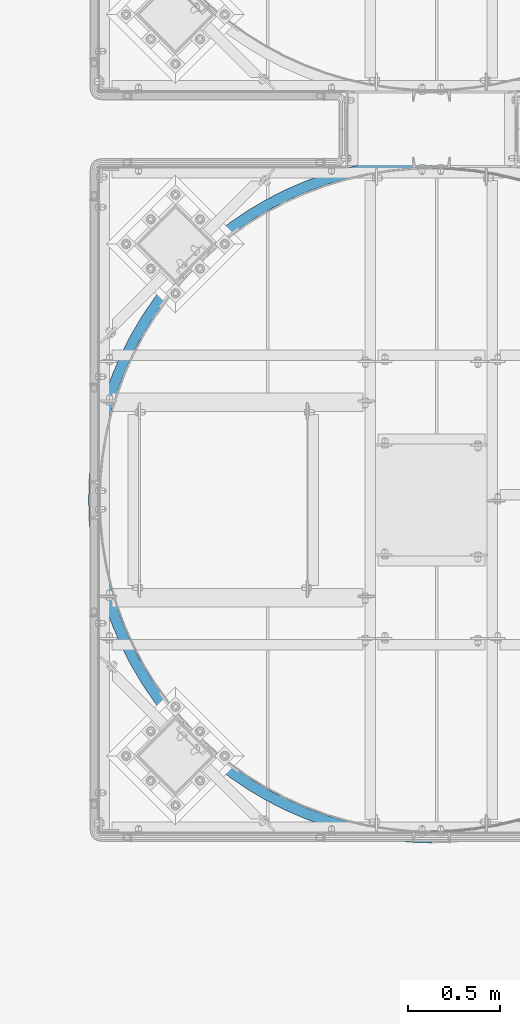
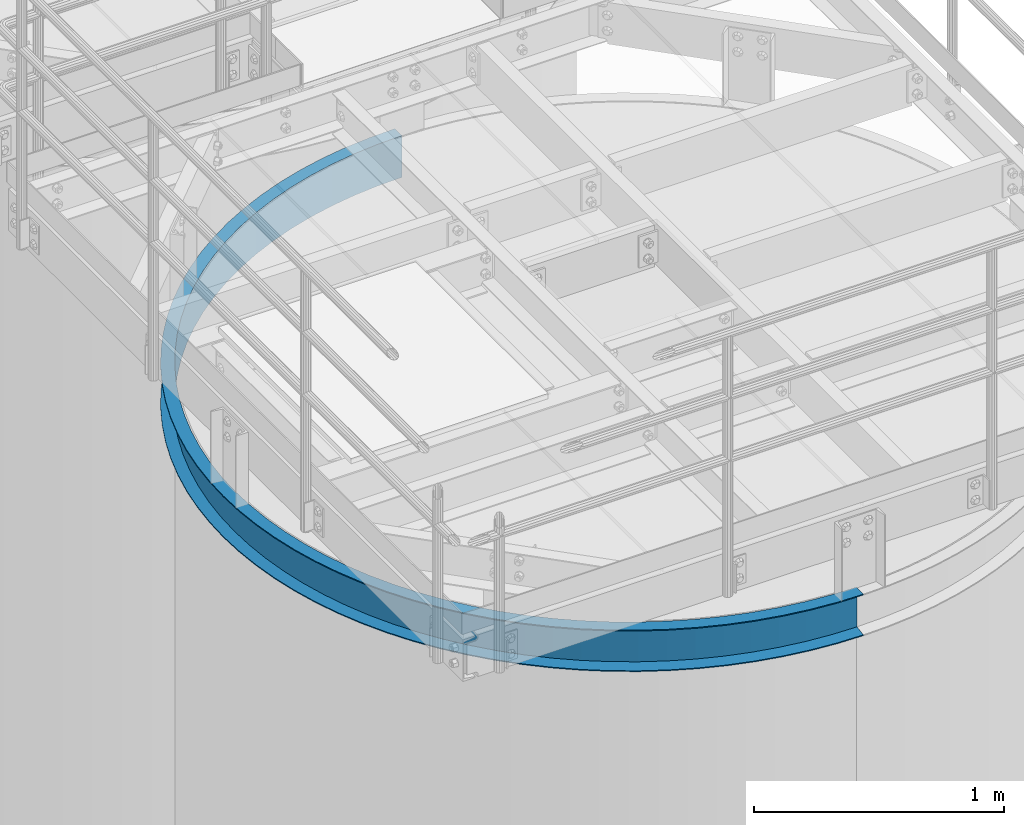
# One storey, part 920 of 1876: 1 beam, 1 element without a shape of its own.
"""IFC2X3 building model written with IfcOpenShell, lengths in millimetres."""

from ifc_helpers import new_model, si_unit, frame, origin_with_axes, place, context, subcontext, project, spatial, faceted_brep, material, type_object, element, aggregate, save


model = new_model("IFC2X3")

# Units and contexts
model_context = context("Model", 3, precision=1e-05, world=origin_with_axes())
body_context = subcontext(model_context, "Body", "Model", "MODEL_VIEW")
ifc_project = project(units=[si_unit("LENGTHUNIT", "METRE", prefix="MILLI"), si_unit("AREAUNIT", "SQUARE_METRE"), si_unit("VOLUMEUNIT", "CUBIC_METRE"), si_unit("MASSUNIT", "GRAM", prefix="KILO"), si_unit("TIMEUNIT", "SECOND"), si_unit("PLANEANGLEUNIT", "RADIAN"), si_unit("SOLIDANGLEUNIT", "STERADIAN"), si_unit("THERMODYNAMICTEMPERATUREUNIT", "DEGREE_CELSIUS"), si_unit("LUMINOUSINTENSITYUNIT", "LUMEN")], contexts=[model_context])

# Site, building, storey
site_placement = place(None, origin_with_axes())
site = spatial("IfcSite", under=ifc_project, at=site_placement, CompositionType="ELEMENT")
building_placement = place(site_placement, origin_with_axes())
building = spatial("IfcBuilding", under=site, at=building_placement, Name="Undefined", CompositionType="ELEMENT")
storey_placement = place(building_placement, origin_with_axes())
storey = spatial("IfcBuildingStorey", under=building, at=storey_placement, Name="Undefined", CompositionType="ELEMENT", Elevation=0.0)

# Assembly, beam
assembly_placement = place(storey_placement, origin_with_axes())
assembly = element("IfcElementAssembly", 1, at=assembly_placement, inside=storey, Name="CHANNEL", AssemblyPlace="NOTDEFINED", PredefinedType="RIGID_FRAME")
ifc_material = material(Name="STEEL/A36")
beam_type = type_object("IfcBeamType", Name="C8X11.5", PredefinedType="NOTDEFINED")
beam_placement = place(assembly_placement, frame((5161.39583081535, -15425.2699805693, 7518.41566278096), z_axis=(0.0, 0.0, -1.0), x_axis=(-0.707106781186548, 0.707106781186547, 0.0)))
beam = element("IfcBeam", 2, at=beam_placement, type_object=beam_type, material=ifc_material, Name="CHANNEL", ObjectType="C8X11.5", context=body_context, shape_type="Brep", body=[
    faceted_brep([(-40.4111525448152, -11.8361525448254, -101.6), (-40.4111525448152, -11.8361525448254, -96.8355949999996), (-4.49012806054634, 24.0848719394708, -88.3723149999996), (-4.49012806054634, 24.0848719394708, 88.3723149999996), (-40.4111525448152, -11.8361525448254, 96.8355949999996), (-40.4111525448152, -11.8361525448254, 101.6), (0.0, 28.5749999999998, 101.6), (0.0, 28.5749999999998, -101.6), (83.1681455805992, -49.5250871930584, 101.6), (83.168145580601, -49.5250871930593, -101.6), (45.3741724773627, -92.3939348224612, -101.6), (45.3741724773627, -92.3939348224612, -96.8355949999996), (78.9688152357958, -54.2882924852147, -88.3723149999996), (78.9688152357958, -54.2882924852147, 88.3723149999996), (45.3741724773627, -92.3939348224612, 96.8355949999996), (45.3741724773627, -92.3939348224612, 101.6), (136.048484757743, -167.406249592315, 96.8355949999996), (136.048484757743, -167.406249592315, 101.6), (167.184163083306, -127.266374963614, 88.3723149999996), (167.184163083306, -127.266374963614, -88.3723149999996), (136.048484757743, -167.406249592315, -96.8355949999996), (136.048484757743, -167.406249592315, -101.6), (171.076122874001, -122.248890635026, 101.6), (171.076122874001, -122.248890635026, -101.6), (231.253934210907, -236.577057517859, 96.8355949999996), (231.253934210907, -236.577057517859, 101.6), (259.807769805786, -194.561364344698, 88.3723149999996), (259.807769805786, -194.561364344698, -88.3723149999996), (231.253934210907, -236.577057517859, -96.8355949999996), (231.253934210907, -236.577057517859, -101.6), (263.376999255146, -189.309402698053, 101.6), (263.376999255146, -189.309402698053, -101.6), (330.614788423094, -299.633373021349, 96.8355949999996), (330.614788423094, -299.633373021349, 101.6), (356.474092343207, -255.907678049534, 88.3723149999996), (356.474092343207, -255.907678049534, -88.3723149999996), (330.614788423094, -299.633373021349, -96.8355949999996), (330.614788423094, -299.633373021349, -101.6), (359.706505333223, -250.441966178058, 101.6), (359.706505333223, -250.441966178058, -101.6), (433.738915496391, -356.326341633181, 96.8355949999996), (433.738915496391, -356.326341633181, 101.6), (456.801632883155, -311.063210204398, 88.3723149999996), (456.801632883155, -311.063210204398, -88.3723149999996), (433.738915496391, -356.326341633181, -96.8355949999996), (433.738915496391, -356.326341633181, -101.6), (459.684472556501, -305.4053187758, 101.6), (459.684472556501, -305.4053187758, -101.6), (540.219331614169, -406.432222106796, 96.8355949999996), (540.219331614169, -406.432222106796, 101.6), (560.39444445841, -359.810287122038, 88.3723149999996), (560.39444445841, -359.810287122038, -88.3723149999996), (540.219331614169, -406.432222106796, -96.8355949999996), (540.219331614169, -406.432222106796, -101.6), (562.91633356394, -353.982545248944, 101.6), (562.91633356394, -353.982545248944, -101.6), (649.635807220287, -449.753269423169, 96.8355949999996), (649.635807220287, -449.753269423169, 101.6), (666.843693568744, -401.956526360284, 88.3723149999996), (666.843693568744, -401.956526360284, -88.3723149999996), (649.635807220287, -449.753269423169, -96.8355949999996), (649.635807220287, -449.753269423169, -101.6), (668.9946793623, -395.981933477424, 101.6), (668.9946793623, -395.981933477424, -101.6), (761.556525473163, -486.118515200043, 96.8355949999996), (761.556525473163, -486.118515200043, 101.6), (775.729273659952, -437.335595967645, 88.3723149999996), (775.729273659952, -437.335595967645, -88.3723149999996), (761.556525473163, -486.118515200043, -96.8355949999996), (761.556525473163, -486.118515200043, -101.6), (777.500867183298, -431.237731063595, 101.6), (777.500867183298, -431.237731063595, -101.6), (875.539786429559, -515.384442426039, 96.8355949999996), (875.539786429559, -515.384442426039, 101.6), (886.621463092501, -465.807870919541, 88.3723149999996), (886.621463092501, -465.807870919541, -88.3723149999996), (875.539786429559, -515.384442426039, -96.8355949999996), (875.539786429559, -515.384442426039, -101.6), (888.006672675367, -459.610799481228, 101.6), (888.006672675367, -459.610799481228, -101.6), (991.135750232484, -537.435551856724, 96.8355949999996), (991.135750232484, -537.435551856724, 101.6), (999.082621056526, -487.260984154484, 88.3723149999996), (999.082621056526, -487.260984154484, -88.3723149999996), (991.135750232484, -537.435551856724, -96.8355949999996), (991.135750232484, -537.435551856724, -101.6), (1000.07597990953, -480.989163191702, 101.6), (1000.07597990953, -480.989163191702, -101.6), (1107.88821242358, -552.184817837371, 96.8355949999996), (1107.88821242358, -552.184817837371, 101.6), (1112.66891474016, -501.610270035526, 88.3723149999996), (1112.66891474016, -501.610270035526, -88.3723149999996), (1107.88821242358, -552.184817837371, -96.8355949999996), (1107.88821242358, -552.184817837371, -101.6), (1113.26650252974, -495.288451560295, 101.6), (1113.26650252974, -495.288451560295, -101.6), (1225.33640437371, -559.574031753455, 96.8355949999996), (1225.33640437371, -559.574031753455, 101.6), (1226.93207093488, -508.799098486866, 88.3723149999996), (1226.93207093488, -508.799098486866, -88.3723149999996), (1225.33640437371, -559.574031753455, -96.8355949999996), (1225.33640437371, -559.574031753455, -101.6), (1227.13152925503, -502.452231828542, 101.6), (1227.13152925503, -502.452231828542, -101.6), (1343.01681172622, -559.574031753454, 96.8355949999996), (1343.01681172622, -559.574031753454, 101.6), (1341.42114516505, -508.799098486867, 88.3723149999996), (1341.42114516505, -508.799098486867, -88.3723149999996), (1343.01681172622, -559.574031753454, -96.8355949999996), (1343.01681172622, -559.574031753454, -101.6), (1341.2216868449, -502.452231828544, 101.6), (1341.2216868449, -502.452231828544, -101.6), (1460.46500367634, -552.184817837373, 96.8355949999996), (1460.46500367634, -552.184817837373, 101.6), (1455.68430135976, -501.610270035527, 88.3723149999996), (1455.68430135976, -501.610270035527, -88.3723149999996), (1460.46500367634, -552.184817837373, -96.8355949999996), (1460.46500367634, -552.184817837373, -101.6), (1455.08671357019, -495.288451560297, 101.6), (1455.08671357019, -495.288451560297, -101.6), (1577.21746586744, -537.435551856726, 96.8355949999996), (1577.21746586744, -537.435551856726, 101.6), (1569.2705950434, -487.260984154484, 88.3723149999996), (1569.2705950434, -487.260984154484, -88.3723149999996), (1577.21746586744, -537.435551856726, -96.8355949999996), (1577.21746586744, -537.435551856726, -101.6), (1568.27723619039, -480.989163191705, 101.6), (1568.27723619039, -480.989163191705, -101.6), (1692.81342967037, -515.384442426042, 96.8355949999996), (1692.81342967037, -515.384442426042, 101.6), (1681.73175300743, -465.807870919543, 88.3723149999996), (1681.73175300743, -465.807870919543, -88.3723149999996), (1692.81342967037, -515.384442426042, -96.8355949999996), (1692.81342967037, -515.384442426042, -101.6), (1680.34654342456, -459.610799481231, 101.6), (1680.34654342456, -459.610799481231, -101.6), (1806.79669062676, -486.118515200047, 96.8355949999996), (1806.79669062676, -486.118515200047, 101.6), (1792.62394243998, -437.335595967647, 88.3723149999996), (1792.62394243998, -437.335595967647, -88.3723149999996), (1806.79669062676, -486.118515200047, -96.8355949999996), (1806.79669062676, -486.118515200047, -101.6), (1790.85234891663, -431.237731063598, 101.6), (1790.85234891663, -431.237731063598, -101.6), (1918.71740887964, -449.753269423174, 96.8355949999996), (1918.71740887964, -449.753269423174, 101.6), (1901.50952253118, -401.956526360288, 88.3723149999996), (1901.50952253118, -401.956526360288, -88.3723149999996), (1918.71740887964, -449.753269423174, -96.8355949999996), (1918.71740887964, -449.753269423174, -101.6), (1899.35853673763, -395.981933477428, 101.6), (1899.35853673763, -395.981933477428, -101.6), (2028.13388448576, -406.432222106803, 96.8355949999996), (2028.13388448576, -406.432222106803, 101.6), (2007.95877164152, -359.810287122044, 88.3723149999996), (2007.95877164152, -359.810287122044, -88.3723149999996), (2028.13388448576, -406.432222106803, -96.8355949999996), (2028.13388448576, -406.432222106803, -101.6), (2005.43688253599, -353.982545248949, 101.6), (2005.43688253599, -353.982545248949, -101.6), (2134.61430060353, -356.326341633187, 96.8355949999996), (2134.61430060353, -356.326341633187, 101.6), (2111.55158321677, -311.063210204405, 88.3723149999996), (2111.55158321677, -311.063210204405, -88.3723149999996), (2134.61430060353, -356.326341633187, -96.8355949999996), (2134.61430060353, -356.326341633187, -101.6), (2108.66874354343, -305.405318775807, 101.6), (2108.66874354343, -305.405318775807, -101.6), (2237.73842767683, -299.633373021357, 96.8355949999996), (2237.73842767683, -299.633373021357, 101.6), (2211.87912375672, -255.907678049542, 88.3723149999996), (2211.87912375672, -255.907678049542, -88.3723149999996), (2237.73842767683, -299.633373021357, -96.8355949999996), (2237.73842767683, -299.633373021357, -101.6), (2208.64671076671, -250.441966178065, 101.6), (2208.64671076671, -250.441966178065, -101.6), (2337.09928188902, -236.577057517868, 96.8355949999996), (2337.09928188902, -236.577057517868, 101.6), (2308.54544629414, -194.561364344705, 88.3723149999996), (2308.54544629414, -194.561364344705, -88.3723149999996), (2337.09928188902, -236.577057517868, -96.8355949999996), (2337.09928188902, -236.577057517868, -101.6), (2304.97621684478, -189.30940269806, 101.6), (2304.97621684478, -189.30940269806, -101.6), (2432.30473134219, -167.406249592324, 96.8355949999996), (2432.30473134219, -167.406249592324, 101.6), (2401.16905301662, -127.266374963622, 88.3723149999996), (2401.16905301662, -127.266374963622, -88.3723149999996), (2432.30473134219, -167.406249592324, -96.8355949999996), (2432.30473134219, -167.406249592324, -101.6), (2397.27709322593, -122.248890635034, 101.6), (2397.27709322593, -122.248890635034, -101.6), (2522.97904362256, -92.3939348224685, 96.8355949999996), (2522.97904362256, -92.3939348224685, 101.6), (2489.38440086413, -54.2882924852247, 88.3723149999996), (2489.38440086413, -54.2882924852247, -88.3723149999996), (2522.97904362256, -92.3939348224685, -96.8355949999996), (2522.97904362256, -92.3939348224685, -101.6), (2485.18507051933, -49.5250871930684, 101.6), (2485.18507051933, -49.5250871930684, -101.6), (2608.76436864474, -11.8361525448345, 96.8355949999996), (2608.76436864474, -11.8361525448345, 101.6), (2572.84334416047, 24.0848719394626, 88.3723149999996), (2572.84334416047, 24.0848719394626, -88.3723149999996), (2608.76436864474, -11.8361525448345, -96.8355949999996), (2608.76436864474, -11.8361525448345, -101.6), (2568.35321609994, 28.5749999999989, 101.6), (2568.35321609993, 28.5749999999989, -101.6), (2764.3344656923, 164.623484757718, 101.6), (2833.50527361787, 259.828934210873, 101.6), (2896.56158912139, 359.189788423056, 101.6), (2953.25455773324, 462.313915496351, 101.6), (3003.36043820688, 568.794331614128, 101.6), (3046.68148552328, 678.210807220248, 101.6), (3083.04673130017, 790.131525473126, 101.6), (3112.31265852618, 904.114786429529, 101.6), (3134.36376795688, 1019.71075023246, 101.6), (3149.11303393754, 1136.46321242357, 101.6), (3156.50224785364, 1253.91140437371, 101.6), (3156.50224785364, 1371.59181172622, 101.6), (3149.11303393757, 1489.04000367636, 101.6), (3134.36376795692, 1605.79246586747, 101.6), (3112.31265852624, 1721.38842967041, 101.6), (3083.04673130024, 1835.37169062681, 101.6), (3046.68148552336, 1947.2924088797, 101.6), (3003.36043820698, 2056.70888448582, 101.6), (2953.25455773336, 2163.18930060361, 101.6), (2896.56158912152, 2266.31342767691, 101.6), (2833.50527361802, 2365.67428188911, 101.6), (2764.33446569245, 2460.87973134227, 101.6), (2689.32215092258, 2551.55404362265, 101.6), (2608.76436864493, 2637.33936864483, 101.6), (2568.3532161001, 2596.92821610002, 101.6), (2646.45330329319, 2513.76007051941, 101.6), (2719.17710673517, 2425.85209322601, 101.6), (2786.23761879821, 2333.55121684486, 101.6), (2847.37018227823, 2237.22171076678, 101.6), (2902.33353487598, 2137.2437435435, 101.6), (2950.91076134913, 2034.01188253605, 101.6), (2992.91014957762, 1927.93353673768, 101.6), (3028.16594716379, 1819.42734891668, 101.6), (3056.53901558143, 1708.9215434246, 101.6), (3077.9173792919, 1596.85223619042, 101.6), (3092.21666766049, 1483.66171357021, 101.6), (3099.38044792873, 1369.79668684491, 101.6), (3099.38044792872, 1255.70652925503, 101.6), (3092.21666766047, 1141.84150252973, 101.6), (3077.91737929186, 1028.65097990952, 101.6), (3056.53901558137, 916.581672675346, 101.6), (3028.16594716372, 806.075867183273, 101.6), (2992.91014957753, 697.569679362271, 101.6), (2950.91076134903, 591.49133356391, 101.6), (2902.33353487587, 488.25947255647, 101.6), (2847.3701822781, 388.281505333194, 101.6), (2786.23761879807, 291.951999255124, 101.6), (2719.17710673502, 199.651122873987, 101.6), (2646.45330329302, 111.743145580598, 101.6), (2689.32215092242, 73.9491724773488, 101.6), (2646.45330329302, 111.743145580598, -101.6), (2719.17710673502, 199.651122873987, -101.6), (2786.23761879807, 291.951999255124, -101.6), (2847.3701822781, 388.281505333194, -101.6), (2902.33353487587, 488.25947255647, -101.6), (2950.91076134903, 591.49133356391, -101.6), (2992.91014957753, 697.569679362271, -101.6), (3028.16594716372, 806.075867183273, -101.6), (3056.53901558137, 916.581672675346, -101.6), (3077.91737929186, 1028.65097990952, -101.6), (3092.21666766047, 1141.84150252973, -101.6), (3099.38044792872, 1255.70652925503, -101.6), (3099.38044792873, 1369.79668684491, -101.6), (3092.21666766049, 1483.66171357021, -101.6), (3077.9173792919, 1596.85223619042, -101.6), (3056.53901558143, 1708.9215434246, -101.6), (3028.16594716379, 1819.42734891668, -101.6), (2992.91014957762, 1927.93353673768, -101.6), (2950.91076134913, 2034.01188253605, -101.6), (2902.33353487598, 2137.2437435435, -101.6), (2847.37018227823, 2237.22171076678, -101.6), (2786.23761879821, 2333.55121684486, -101.6), (2719.17710673517, 2425.85209322601, -101.6), (2646.45330329319, 2513.76007051941, -101.6), (2568.3532161001, 2596.92821610002, -101.6), (2608.76436864493, 2637.33936864483, -101.6), (2689.32215092258, 2551.55404362265, -101.6), (2764.33446569245, 2460.87973134227, -101.6), (2833.50527361802, 2365.67428188911, -101.6), (2896.56158912152, 2266.31342767691, -101.6), (2953.25455773336, 2163.18930060361, -101.6), (3003.36043820698, 2056.70888448582, -101.6), (3046.68148552336, 1947.2924088797, -101.6), (3083.04673130024, 1835.37169062681, -101.6), (3112.31265852624, 1721.38842967041, -101.6), (3134.36376795692, 1605.79246586747, -101.6), (3149.11303393757, 1489.04000367636, -101.6), (3156.50224785364, 1371.59181172622, -101.6), (3156.50224785364, 1253.91140437371, -101.6), (3149.11303393754, 1136.46321242357, -101.6), (3134.36376795688, 1019.71075023246, -101.6), (3112.31265852618, 904.114786429529, -101.6), (3083.04673130017, 790.131525473126, -101.6), (3046.68148552328, 678.210807220248, -101.6), (3003.36043820688, 568.794331614128, -101.6), (2953.25455773324, 462.313915496351, -101.6), (2896.56158912139, 359.189788423056, -101.6), (2833.50527361787, 259.828934210873, -101.6), (2764.3344656923, 164.623484757718, -101.6), (2689.32215092242, 73.9491724773488, -101.6), (2689.32215092242, 73.9491724773488, -96.8355949999996), (2651.21650858518, 107.543815235792, -88.3723149999996), (2651.21650858518, 107.543815235792, 88.3723149999996), (2689.32215092242, 73.9491724773488, 96.8355949999996), (2764.3344656923, 164.623484757718, 96.8355949999996), (2724.19459106361, 195.75916308329, 88.3723149999996), (2724.19459106361, 195.75916308329, -88.3723149999996), (2764.3344656923, 164.623484757718, -96.8355949999996), (2833.50527361787, 259.828934210873, 96.8355949999996), (2791.48958044472, 288.382769805763, 88.3723149999996), (2791.48958044472, 288.382769805763, -88.3723149999996), (2833.50527361787, 259.828934210873, -96.8355949999996), (2896.56158912139, 359.189788423056, 96.8355949999996), (2852.83589414958, 385.049092343178, 88.3723149999996), (2852.83589414958, 385.049092343178, -88.3723149999996), (2896.56158912139, 359.189788423056, -96.8355949999996), (2953.25455773324, 462.313915496351, 96.8355949999996), (2907.99142630447, 485.376632883123, 88.3723149999996), (2907.99142630447, 485.376632883123, -88.3723149999996), (2953.25455773324, 462.313915496351, -96.8355949999996), (3003.36043820688, 568.794331614128, 96.8355949999996), (2956.73850322213, 588.969444458379, 88.3723149999996), (2956.73850322213, 588.969444458379, -88.3723149999996), (3003.36043820688, 568.794331614128, -96.8355949999996), (3046.68148552328, 678.210807220248, 96.8355949999996), (2998.88474246039, 695.418693568713, 88.3723149999996), (2998.88474246039, 695.418693568713, -88.3723149999996), (3046.68148552328, 678.210807220248, -96.8355949999996), (3083.04673130017, 790.131525473126, 96.8355949999996), (3034.26381206777, 804.304273659922, 88.3723149999996), (3034.26381206777, 804.304273659922, -88.3723149999996), (3083.04673130017, 790.131525473126, -96.8355949999996), (3112.31265852618, 904.114786429529, 96.8355949999996), (3062.73608701968, 915.196463092477, 88.3723149999996), (3062.73608701968, 915.196463092477, -88.3723149999996), (3112.31265852618, 904.114786429529, -96.8355949999996), (3134.36376795688, 1019.71075023246, 96.8355949999996), (3084.18920025464, 1027.65762105651, 88.3723149999996), (3084.18920025464, 1027.65762105651, -88.3723149999996), (3134.36376795688, 1019.71075023246, -96.8355949999996), (3149.11303393754, 1136.46321242357, 96.8355949999996), (3098.5384861357, 1141.24391474015, 88.3723149999996), (3098.5384861357, 1141.24391474015, -88.3723149999996), (3149.11303393754, 1136.46321242357, -96.8355949999996), (3156.50224785364, 1253.91140437371, 96.8355949999996), (3105.72731458705, 1255.50707093488, 88.3723149999996), (3105.72731458705, 1255.50707093488, -88.3723149999996), (3156.50224785364, 1253.91140437371, -96.8355949999996), (3156.50224785364, 1371.59181172622, 96.8355949999996), (3105.72731458705, 1369.99614516506, 88.3723149999996), (3105.72731458705, 1369.99614516506, -88.3723149999996), (3156.50224785364, 1371.59181172622, -96.8355949999996), (3149.11303393757, 1489.04000367636, 96.8355949999996), (3098.53848613572, 1484.25930135978, 88.3723149999996), (3098.53848613572, 1484.25930135978, -88.3723149999996), (3149.11303393757, 1489.04000367636, -96.8355949999996), (3134.36376795692, 1605.79246586747, 96.8355949999996), (3084.18920025468, 1597.84559504343, 88.3723149999996), (3084.18920025468, 1597.84559504343, -88.3723149999996), (3134.36376795692, 1605.79246586747, -96.8355949999996), (3112.31265852624, 1721.38842967041, 96.8355949999996), (3062.73608701974, 1710.30675300747, 88.3723149999996), (3062.73608701974, 1710.30675300747, -88.3723149999996), (3112.31265852624, 1721.38842967041, -96.8355949999996), (3083.04673130024, 1835.37169062681, 96.8355949999996), (3034.26381206784, 1821.19894244003, 88.3723149999996), (3034.26381206784, 1821.19894244003, -88.3723149999996), (3083.04673130024, 1835.37169062681, -96.8355949999996), (3046.68148552336, 1947.2924088797, 96.8355949999996), (2998.88474246048, 1930.08452253124, 88.3723149999996), (2998.88474246048, 1930.08452253124, -88.3723149999996), (3046.68148552336, 1947.2924088797, -96.8355949999996), (3003.36043820698, 2056.70888448582, 96.8355949999996), (2956.73850322223, 2036.53377164158, 88.3723149999996), (2956.73850322223, 2036.53377164158, -88.3723149999996), (3003.36043820698, 2056.70888448582, -96.8355949999996), (2953.25455773336, 2163.18930060361, 96.8355949999996), (2907.99142630458, 2140.12658321685, 88.3723149999996), (2907.99142630458, 2140.12658321685, -88.3723149999996), (2953.25455773336, 2163.18930060361, -96.8355949999996), (2896.56158912152, 2266.31342767691, 96.8355949999996), (2852.8358941497, 2240.4541237568, 88.3723149999996), (2852.8358941497, 2240.4541237568, -88.3723149999996), (2896.56158912152, 2266.31342767691, -96.8355949999996), (2833.50527361802, 2365.67428188911, 96.8355949999996), (2791.48958044486, 2337.12044629422, 88.3723149999996), (2791.48958044486, 2337.12044629422, -88.3723149999996), (2833.50527361802, 2365.67428188911, -96.8355949999996), (2764.33446569245, 2460.87973134227, 96.8355949999996), (2724.19459106376, 2429.74405301671, 88.3723149999996), (2724.19459106376, 2429.74405301671, -88.3723149999996), (2764.33446569245, 2460.87973134227, -96.8355949999996), (2689.32215092258, 2551.55404362265, 96.8355949999996), (2651.21650858534, 2517.95940086422, 88.3723149999996), (2651.21650858534, 2517.95940086422, -88.3723149999996), (2689.32215092258, 2551.55404362265, -96.8355949999996), (2608.76436864493, 2637.33936864483, 96.8355949999996), (2572.84334416064, 2601.41834416056, 88.3723149999996), (2572.84334416064, 2601.41834416056, -88.3723149999996), (2608.76436864493, 2637.33936864483, -96.8355949999996)], [[[0, 1, 2, 3, 4, 5, 6, 7]], [[7, 6, 8, 9]], [[1, 0, 10, 11]], [[2, 1, 11, 12]], [[3, 2, 12, 13]], [[4, 3, 13, 14]], [[5, 4, 14, 15]], [[14, 16, 17, 15]], [[13, 18, 16, 14]], [[12, 19, 18, 13]], [[11, 20, 19, 12]], [[10, 21, 20, 11]], [[8, 22, 23, 9]], [[16, 24, 25, 17]], [[18, 26, 24, 16]], [[19, 27, 26, 18]], [[20, 28, 27, 19]], [[21, 29, 28, 20]], [[22, 30, 31, 23]], [[24, 32, 33, 25]], [[26, 34, 32, 24]], [[27, 35, 34, 26]], [[28, 36, 35, 27]], [[29, 37, 36, 28]], [[30, 38, 39, 31]], [[32, 40, 41, 33]], [[34, 42, 40, 32]], [[35, 43, 42, 34]], [[36, 44, 43, 35]], [[37, 45, 44, 36]], [[38, 46, 47, 39]], [[40, 48, 49, 41]], [[42, 50, 48, 40]], [[43, 51, 50, 42]], [[44, 52, 51, 43]], [[45, 53, 52, 44]], [[46, 54, 55, 47]], [[48, 56, 57, 49]], [[50, 58, 56, 48]], [[51, 59, 58, 50]], [[52, 60, 59, 51]], [[53, 61, 60, 52]], [[54, 62, 63, 55]], [[56, 64, 65, 57]], [[58, 66, 64, 56]], [[59, 67, 66, 58]], [[60, 68, 67, 59]], [[61, 69, 68, 60]], [[62, 70, 71, 63]], [[64, 72, 73, 65]], [[66, 74, 72, 64]], [[67, 75, 74, 66]], [[68, 76, 75, 67]], [[69, 77, 76, 68]], [[70, 78, 79, 71]], [[72, 80, 81, 73]], [[74, 82, 80, 72]], [[75, 83, 82, 74]], [[76, 84, 83, 75]], [[77, 85, 84, 76]], [[78, 86, 87, 79]], [[80, 88, 89, 81]], [[82, 90, 88, 80]], [[83, 91, 90, 82]], [[84, 92, 91, 83]], [[85, 93, 92, 84]], [[86, 94, 95, 87]], [[88, 96, 97, 89]], [[90, 98, 96, 88]], [[91, 99, 98, 90]], [[92, 100, 99, 91]], [[93, 101, 100, 92]], [[94, 102, 103, 95]], [[96, 104, 105, 97]], [[98, 106, 104, 96]], [[99, 107, 106, 98]], [[100, 108, 107, 99]], [[101, 109, 108, 100]], [[102, 110, 111, 103]], [[104, 112, 113, 105]], [[106, 114, 112, 104]], [[107, 115, 114, 106]], [[108, 116, 115, 107]], [[109, 117, 116, 108]], [[110, 118, 119, 111]], [[112, 120, 121, 113]], [[114, 122, 120, 112]], [[115, 123, 122, 114]], [[116, 124, 123, 115]], [[117, 125, 124, 116]], [[118, 126, 127, 119]], [[120, 128, 129, 121]], [[122, 130, 128, 120]], [[123, 131, 130, 122]], [[124, 132, 131, 123]], [[125, 133, 132, 124]], [[126, 134, 135, 127]], [[128, 136, 137, 129]], [[130, 138, 136, 128]], [[131, 139, 138, 130]], [[132, 140, 139, 131]], [[133, 141, 140, 132]], [[134, 142, 143, 135]], [[136, 144, 145, 137]], [[138, 146, 144, 136]], [[139, 147, 146, 138]], [[140, 148, 147, 139]], [[141, 149, 148, 140]], [[142, 150, 151, 143]], [[144, 152, 153, 145]], [[146, 154, 152, 144]], [[147, 155, 154, 146]], [[148, 156, 155, 147]], [[149, 157, 156, 148]], [[150, 158, 159, 151]], [[152, 160, 161, 153]], [[154, 162, 160, 152]], [[155, 163, 162, 154]], [[156, 164, 163, 155]], [[157, 165, 164, 156]], [[158, 166, 167, 159]], [[160, 168, 169, 161]], [[162, 170, 168, 160]], [[163, 171, 170, 162]], [[164, 172, 171, 163]], [[165, 173, 172, 164]], [[166, 174, 175, 167]], [[168, 176, 177, 169]], [[170, 178, 176, 168]], [[171, 179, 178, 170]], [[172, 180, 179, 171]], [[173, 181, 180, 172]], [[174, 182, 183, 175]], [[176, 184, 185, 177]], [[178, 186, 184, 176]], [[179, 187, 186, 178]], [[180, 188, 187, 179]], [[181, 189, 188, 180]], [[182, 190, 191, 183]], [[184, 192, 193, 185]], [[186, 194, 192, 184]], [[187, 195, 194, 186]], [[188, 196, 195, 187]], [[189, 197, 196, 188]], [[190, 198, 199, 191]], [[192, 200, 201, 193]], [[194, 202, 200, 192]], [[195, 203, 202, 194]], [[196, 204, 203, 195]], [[197, 205, 204, 196]], [[198, 206, 207, 199]], [[208, 209, 210, 211, 212, 213, 214, 215, 216, 217, 218, 219, 220, 221, 222, 223, 224, 225, 226, 227, 228, 229, 230, 231, 232, 233, 234, 235, 236, 237, 238, 239, 240, 241, 242, 243, 244, 245, 246, 247, 248, 249, 250, 251, 252, 253, 254, 255, 256, 206, 198, 190, 182, 174, 166, 158, 150, 142, 134, 126, 118, 110, 102, 94, 86, 78, 70, 62, 54, 46, 38, 30, 22, 8, 6, 5, 15, 17, 25, 33, 41, 49, 57, 65, 73, 81, 89, 97, 105, 113, 121, 129, 137, 145, 153, 161, 169, 177, 185, 193, 201, 257]], [[207, 206, 256, 258]], [[259, 260, 261, 262, 263, 264, 265, 266, 267, 268, 269, 270, 271, 272, 273, 274, 275, 276, 277, 278, 279, 280, 281, 282, 283, 284, 285, 286, 287, 288, 289, 290, 291, 292, 293, 294, 295, 296, 297, 298, 299, 300, 301, 302, 303, 304, 305, 306, 307, 205, 197, 189, 181, 173, 165, 157, 149, 141, 133, 125, 117, 109, 101, 93, 85, 77, 69, 61, 53, 45, 37, 29, 21, 10, 0, 7, 9, 23, 31, 39, 47, 55, 63, 71, 79, 87, 95, 103, 111, 119, 127, 135, 143, 151, 159, 167, 175, 183, 191, 199, 207, 258]], [[204, 205, 307, 308]], [[203, 204, 308, 309]], [[202, 203, 309, 310]], [[200, 202, 310, 311]], [[201, 200, 311, 257]], [[311, 312, 208, 257]], [[310, 313, 312, 311]], [[309, 314, 313, 310]], [[308, 315, 314, 309]], [[307, 306, 315, 308]], [[256, 255, 259, 258]], [[312, 316, 209, 208]], [[313, 317, 316, 312]], [[314, 318, 317, 313]], [[315, 319, 318, 314]], [[306, 305, 319, 315]], [[255, 254, 260, 259]], [[316, 320, 210, 209]], [[317, 321, 320, 316]], [[318, 322, 321, 317]], [[319, 323, 322, 318]], [[305, 304, 323, 319]], [[254, 253, 261, 260]], [[320, 324, 211, 210]], [[321, 325, 324, 320]], [[322, 326, 325, 321]], [[323, 327, 326, 322]], [[304, 303, 327, 323]], [[253, 252, 262, 261]], [[324, 328, 212, 211]], [[325, 329, 328, 324]], [[326, 330, 329, 325]], [[327, 331, 330, 326]], [[303, 302, 331, 327]], [[252, 251, 263, 262]], [[328, 332, 213, 212]], [[329, 333, 332, 328]], [[330, 334, 333, 329]], [[331, 335, 334, 330]], [[302, 301, 335, 331]], [[251, 250, 264, 263]], [[332, 336, 214, 213]], [[333, 337, 336, 332]], [[334, 338, 337, 333]], [[335, 339, 338, 334]], [[301, 300, 339, 335]], [[250, 249, 265, 264]], [[336, 340, 215, 214]], [[337, 341, 340, 336]], [[338, 342, 341, 337]], [[339, 343, 342, 338]], [[300, 299, 343, 339]], [[249, 248, 266, 265]], [[340, 344, 216, 215]], [[341, 345, 344, 340]], [[342, 346, 345, 341]], [[343, 347, 346, 342]], [[299, 298, 347, 343]], [[248, 247, 267, 266]], [[344, 348, 217, 216]], [[345, 349, 348, 344]], [[346, 350, 349, 345]], [[347, 351, 350, 346]], [[298, 297, 351, 347]], [[247, 246, 268, 267]], [[348, 352, 218, 217]], [[349, 353, 352, 348]], [[350, 354, 353, 349]], [[351, 355, 354, 350]], [[297, 296, 355, 351]], [[246, 245, 269, 268]], [[352, 356, 219, 218]], [[353, 357, 356, 352]], [[354, 358, 357, 353]], [[355, 359, 358, 354]], [[296, 295, 359, 355]], [[245, 244, 270, 269]], [[356, 360, 220, 219]], [[357, 361, 360, 356]], [[358, 362, 361, 357]], [[359, 363, 362, 358]], [[295, 294, 363, 359]], [[244, 243, 271, 270]], [[360, 364, 221, 220]], [[361, 365, 364, 360]], [[362, 366, 365, 361]], [[363, 367, 366, 362]], [[294, 293, 367, 363]], [[243, 242, 272, 271]], [[364, 368, 222, 221]], [[365, 369, 368, 364]], [[366, 370, 369, 365]], [[367, 371, 370, 366]], [[293, 292, 371, 367]], [[242, 241, 273, 272]], [[368, 372, 223, 222]], [[369, 373, 372, 368]], [[370, 374, 373, 369]], [[371, 375, 374, 370]], [[292, 291, 375, 371]], [[241, 240, 274, 273]], [[372, 376, 224, 223]], [[373, 377, 376, 372]], [[374, 378, 377, 373]], [[375, 379, 378, 374]], [[291, 290, 379, 375]], [[240, 239, 275, 274]], [[376, 380, 225, 224]], [[377, 381, 380, 376]], [[378, 382, 381, 377]], [[379, 383, 382, 378]], [[290, 289, 383, 379]], [[239, 238, 276, 275]], [[380, 384, 226, 225]], [[381, 385, 384, 380]], [[382, 386, 385, 381]], [[383, 387, 386, 382]], [[289, 288, 387, 383]], [[238, 237, 277, 276]], [[384, 388, 227, 226]], [[385, 389, 388, 384]], [[386, 390, 389, 385]], [[387, 391, 390, 386]], [[288, 287, 391, 387]], [[237, 236, 278, 277]], [[388, 392, 228, 227]], [[389, 393, 392, 388]], [[390, 394, 393, 389]], [[391, 395, 394, 390]], [[287, 286, 395, 391]], [[236, 235, 279, 278]], [[392, 396, 229, 228]], [[393, 397, 396, 392]], [[394, 398, 397, 393]], [[395, 399, 398, 394]], [[286, 285, 399, 395]], [[235, 234, 280, 279]], [[396, 400, 230, 229]], [[397, 401, 400, 396]], [[398, 402, 401, 397]], [[399, 403, 402, 398]], [[285, 284, 403, 399]], [[234, 233, 281, 280]], [[231, 404, 405, 406, 407, 283, 282, 232]], [[400, 404, 231, 230]], [[401, 405, 404, 400]], [[402, 406, 405, 401]], [[403, 407, 406, 402]], [[284, 283, 407, 403]], [[233, 232, 282, 281]]]),
])
aggregate(assembly, [beam])

save(model, "model.ifc")
